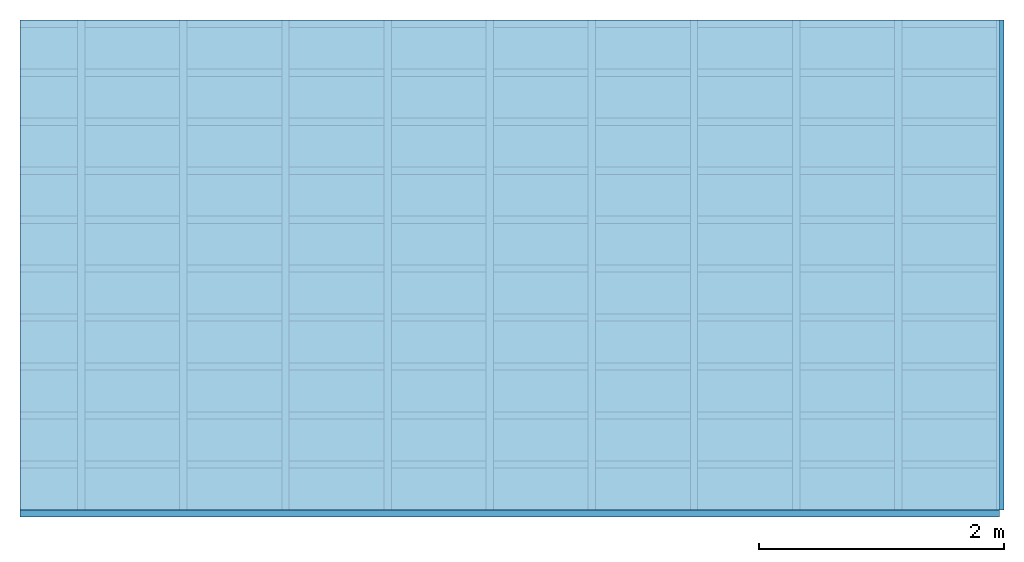
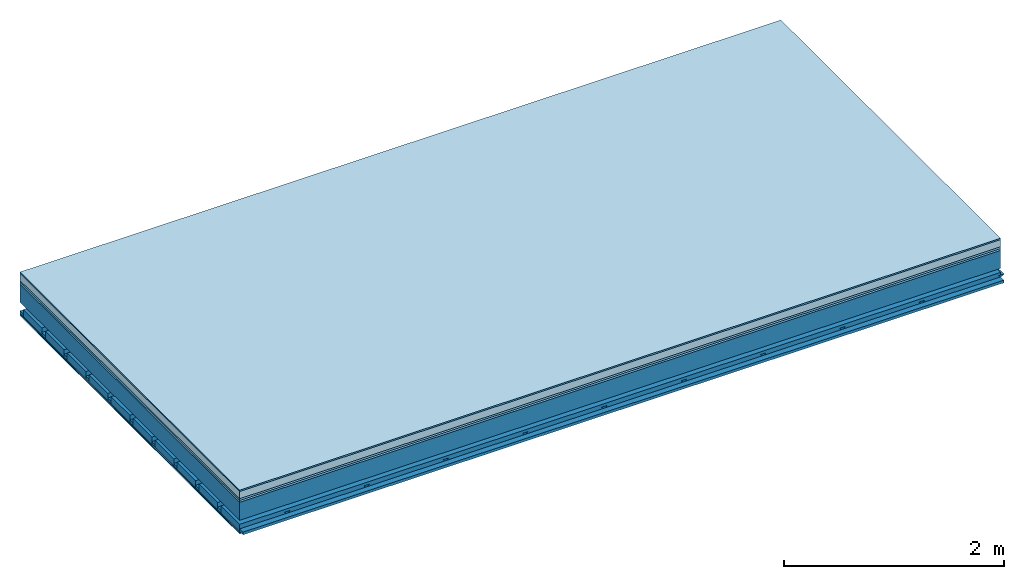
# One storey: 7 plates, 4 members, 1 element without a shape of its own.
"""IFC4 building model written with IfcOpenShell, lengths in metres."""

from ifc_helpers import new_model, si_unit, derived_unit, direction, frame, frame_2d, origin, origin_with_axes, place, context, project, spatial, polyline, rectangle, outline, extrude, material, layer, layer_set, type_object, element, aggregate, save


model = new_model("IFC4")

# Units and contexts
plan_context = context("Plan", 3, precision=1e-05, world=origin(), true_north=direction((0.0, 1.0)))
model_context = context("Model", 3, precision=1e-05, world=origin(), true_north=direction((0.0, 1.0)))
ifc_project = project(units=[si_unit("LENGTHUNIT", "METRE"), derived_unit("SOUNDPRESSUREUNIT", [(si_unit("PRESSUREUNIT", "PASCAL", prefix="MICRO"), 0)]), si_unit("ENERGYUNIT", "JOULE", prefix="MEGA"), si_unit("MASSUNIT", "GRAM", prefix="KILO"), derived_unit("THERMALTRANSMITTANCEUNIT", [(si_unit("POWERUNIT", "WATT"), 1), (si_unit("AREAUNIT", "SQUARE_METRE"), -1), (si_unit("THERMODYNAMICTEMPERATUREUNIT", "KELVIN"), -1)]), derived_unit("AREADENSITYUNIT", [(si_unit("MASSUNIT", "GRAM", prefix="KILO"), 1), (si_unit("AREAUNIT", "SQUARE_METRE"), -1)]), derived_unit("USERDEFINED", [(si_unit("ENERGYUNIT", "JOULE", prefix="MEGA"), 1), (si_unit("AREAUNIT", "SQUARE_METRE"), -1)])], contexts=[plan_context, model_context])

# Site, building, storey
site = spatial("IfcSite", under=ifc_project)
building_placement = place(None, origin())
building = spatial("IfcBuilding", under=site, at=building_placement)
storey_placement = place(building_placement, origin())
storey = spatial("IfcBuildingStorey", under=building, at=storey_placement)

# Slab, members, plates
ifc_material_1 = material(Category="11.013")
ifc_layer_1 = layer(ifc_material_1, 0.015, Name="Flooring")
ifc_material_2 = material(Name="Cement screed", Category="04.006")
ifc_layer_2 = layer(ifc_material_2, 0.08, Name="On-material")
ifc_material_3 = material(Name="Wood fiber generic product", Category="10.009")
ifc_layer_3 = layer(ifc_material_3, 0.02, Name="Impact sound insulation")
ifc_material_4 = material(Category="10.004")
ifc_layer_4 = layer(ifc_material_4, 0.02, Name="Additional insulation")
ifc_material_5 = material(Name="no composite action")
ifc_layer_5 = layer(ifc_material_5, 0.0, Name="Bond")
ifc_layer_6 = layer(None, 0.2, Name="Supporting structure")
ifc_layer_7 = layer(ifc_material_5, 0.0, Name="Bond")
ifc_layer_8 = layer(None, 0.095, Name="Coupling")
ifc_layer_9 = layer(None, 0.03, Name="Battens / profiles")
ifc_material_6 = material(Name="Plasterboard type A", Category="03.008")
ifc_layer_10 = layer(ifc_material_6, 0.0125, Name="Ceiling covering 1st layer")
ifc_layer_11 = layer(ifc_material_6, 0.0125, Name="Ceiling covering layer 2")
ifc_material_7 = material(Category="04.001")
ifc_layer_12 = layer(ifc_material_7, 0.003, Name="Surface / treatment")
ifc_layer_set = layer_set([ifc_layer_1, ifc_layer_2, ifc_layer_3, ifc_layer_4, ifc_layer_5, ifc_layer_6, ifc_layer_7, ifc_layer_8, ifc_layer_9, ifc_layer_10, ifc_layer_11, ifc_layer_12])
slab_type = type_object("IfcSlabType", Name="A2154", PredefinedType="NOTDEFINED", material=ifc_layer_set)
slab_placement = place(None, frame((0.0, 0.0, 0.0), z_axis=(0.0, 0.0, -1.0), x_axis=(1.0, 0.0, 0.0)))
slab = element("IfcSlab", 1, at=slab_placement, inside=storey, type_object=slab_type, material=ifc_layer_set, Name="Slab #1")
ifc_material_8 = material(Name="Solid timber panel")
member_1_placement = place(slab_placement, origin())
member_1 = element("IfcMember", 2, at=member_1_placement, material=ifc_material_8, Name="Supporting structure", context=plan_context, shape_type="SweptSolid", body=[
    extrude(rectangle(XDim=1.0, YDim=0.2, at=frame_2d((0.5, 0.1), x_axis=(1.0, 0.0))), frame((0.0, 4.0, 0.135), z_axis=(0.0, -1.0, 0.0), x_axis=(1.0, 0.0, 0.0)), (0.0, 0.0, 1.0), 4.0),
    extrude(rectangle(XDim=1.0, YDim=0.2, at=frame_2d((0.5, 0.1), x_axis=(1.0, 0.0))), frame((1.0, 4.0, 0.135), z_axis=(0.0, -1.0, 0.0), x_axis=(1.0, 0.0, 0.0)), (0.0, 0.0, 1.0), 4.0),
    extrude(rectangle(XDim=1.0, YDim=0.2, at=frame_2d((0.5, 0.1), x_axis=(1.0, 0.0))), frame((2.0, 4.0, 0.135), z_axis=(0.0, -1.0, 0.0), x_axis=(1.0, 0.0, 0.0)), (0.0, 0.0, 1.0), 4.0),
    extrude(rectangle(XDim=1.0, YDim=0.2, at=frame_2d((0.5, 0.1), x_axis=(1.0, 0.0))), frame((3.0, 4.0, 0.135), z_axis=(0.0, -1.0, 0.0), x_axis=(1.0, 0.0, 0.0)), (0.0, 0.0, 1.0), 4.0),
    extrude(rectangle(XDim=1.0, YDim=0.2, at=frame_2d((0.5, 0.1), x_axis=(1.0, 0.0))), frame((4.0, 4.0, 0.135), z_axis=(0.0, -1.0, 0.0), x_axis=(1.0, 0.0, 0.0)), (0.0, 0.0, 1.0), 4.0),
    extrude(rectangle(XDim=1.0, YDim=0.2, at=frame_2d((0.5, 0.1), x_axis=(1.0, 0.0))), frame((5.0, 4.0, 0.135), z_axis=(0.0, -1.0, 0.0), x_axis=(1.0, 0.0, 0.0)), (0.0, 0.0, 1.0), 4.0),
    extrude(rectangle(XDim=1.0, YDim=0.2, at=frame_2d((0.5, 0.1), x_axis=(1.0, 0.0))), frame((6.0, 4.0, 0.135), z_axis=(0.0, -1.0, 0.0), x_axis=(1.0, 0.0, 0.0)), (0.0, 0.0, 1.0), 4.0),
    extrude(rectangle(XDim=1.0, YDim=0.2, at=frame_2d((0.5, 0.1), x_axis=(1.0, 0.0))), frame((7.0, 4.0, 0.135), z_axis=(0.0, -1.0, 0.0), x_axis=(1.0, 0.0, 0.0)), (0.0, 0.0, 1.0), 4.0),
])
ifc_material_9 = material()
member_2_placement = place(slab_placement, origin())
member_2 = element("IfcMember", 3, at=member_2_placement, material=ifc_material_9, Name="Coupling", context=plan_context, shape_type="SweptSolid", body=[
    extrude(outline(polyline([(0.0, 0.0), (0.06, 0.0), (0.04, 0.02), (0.02, 0.02), (0.0, 0.0)])), frame((0.47, 4.0, 0.41), z_axis=(0.0, -1.0, 0.0), x_axis=(1.0, 0.0, 0.0)), (0.0, 0.0, 1.0), 4.0),
    extrude(outline(polyline([(0.0, 0.0), (0.06, 0.0), (0.04, 0.02), (0.02, 0.02), (0.0, 0.0)])), frame((1.304, 4.0, 0.41), z_axis=(0.0, -1.0, 0.0), x_axis=(1.0, 0.0, 0.0)), (0.0, 0.0, 1.0), 4.0),
    extrude(outline(polyline([(0.0, 0.0), (0.06, 0.0), (0.04, 0.02), (0.02, 0.02), (0.0, 0.0)])), frame((2.138, 4.0, 0.41), z_axis=(0.0, -1.0, 0.0), x_axis=(1.0, 0.0, 0.0)), (0.0, 0.0, 1.0), 4.0),
    extrude(outline(polyline([(0.0, 0.0), (0.06, 0.0), (0.04, 0.02), (0.02, 0.02), (0.0, 0.0)])), frame((2.972, 4.0, 0.41), z_axis=(0.0, -1.0, 0.0), x_axis=(1.0, 0.0, 0.0)), (0.0, 0.0, 1.0), 4.0),
    extrude(outline(polyline([(0.0, 0.0), (0.06, 0.0), (0.04, 0.02), (0.02, 0.02), (0.0, 0.0)])), frame((3.806, 4.0, 0.41), z_axis=(0.0, -1.0, 0.0), x_axis=(1.0, 0.0, 0.0)), (0.0, 0.0, 1.0), 4.0),
    extrude(outline(polyline([(0.0, 0.0), (0.06, 0.0), (0.04, 0.02), (0.02, 0.02), (0.0, 0.0)])), frame((4.64, 4.0, 0.41), z_axis=(0.0, -1.0, 0.0), x_axis=(1.0, 0.0, 0.0)), (0.0, 0.0, 1.0), 4.0),
    extrude(outline(polyline([(0.0, 0.0), (0.06, 0.0), (0.04, 0.02), (0.02, 0.02), (0.0, 0.0)])), frame((5.474, 4.0, 0.41), z_axis=(0.0, -1.0, 0.0), x_axis=(1.0, 0.0, 0.0)), (0.0, 0.0, 1.0), 4.0),
    extrude(outline(polyline([(0.0, 0.0), (0.06, 0.0), (0.04, 0.02), (0.02, 0.02), (0.0, 0.0)])), frame((6.308, 4.0, 0.41), z_axis=(0.0, -1.0, 0.0), x_axis=(1.0, 0.0, 0.0)), (0.0, 0.0, 1.0), 4.0),
    extrude(outline(polyline([(0.0, 0.0), (0.06, 0.0), (0.04, 0.02), (0.02, 0.02), (0.0, 0.0)])), frame((7.142, 4.0, 0.41), z_axis=(0.0, -1.0, 0.0), x_axis=(1.0, 0.0, 0.0)), (0.0, 0.0, 1.0), 4.0),
    extrude(outline(polyline([(0.0, 0.0), (0.06, 0.0), (0.04, 0.02), (0.02, 0.02), (0.0, 0.0)])), frame((7.976, 4.0, 0.41), z_axis=(0.0, -1.0, 0.0), x_axis=(1.0, 0.0, 0.0)), (0.0, 0.0, 1.0), 4.0),
])
member_3_placement = place(slab_placement, origin())
member_3 = element("IfcMember", 4, at=member_3_placement, material=ifc_material_9, Name="Battens / profiles", context=plan_context, shape_type="SweptSolid", body=[
    extrude(rectangle(XDim=0.06, YDim=0.03, at=frame_2d((0.03, 0.015), x_axis=(1.0, 0.0))), frame((0.0, 0.0, 0.43), z_axis=(1.0, 0.0, 0.0), x_axis=(0.0, 1.0, 0.0)), (0.0, 0.0, 1.0), 8.0),
    extrude(rectangle(XDim=0.06, YDim=0.03, at=frame_2d((0.03, 0.015), x_axis=(1.0, 0.0))), frame((0.0, 0.4, 0.43), z_axis=(1.0, 0.0, 0.0), x_axis=(0.0, 1.0, 0.0)), (0.0, 0.0, 1.0), 8.0),
    extrude(rectangle(XDim=0.06, YDim=0.03, at=frame_2d((0.03, 0.015), x_axis=(1.0, 0.0))), frame((0.0, 0.8, 0.43), z_axis=(1.0, 0.0, 0.0), x_axis=(0.0, 1.0, 0.0)), (0.0, 0.0, 1.0), 8.0),
    extrude(rectangle(XDim=0.06, YDim=0.03, at=frame_2d((0.03, 0.015), x_axis=(1.0, 0.0))), frame((0.0, 1.2, 0.43), z_axis=(1.0, 0.0, 0.0), x_axis=(0.0, 1.0, 0.0)), (0.0, 0.0, 1.0), 8.0),
    extrude(rectangle(XDim=0.06, YDim=0.03, at=frame_2d((0.03, 0.015), x_axis=(1.0, 0.0))), frame((0.0, 1.6, 0.43), z_axis=(1.0, 0.0, 0.0), x_axis=(0.0, 1.0, 0.0)), (0.0, 0.0, 1.0), 8.0),
    extrude(rectangle(XDim=0.06, YDim=0.03, at=frame_2d((0.03, 0.015), x_axis=(1.0, 0.0))), frame((0.0, 2.0, 0.43), z_axis=(1.0, 0.0, 0.0), x_axis=(0.0, 1.0, 0.0)), (0.0, 0.0, 1.0), 8.0),
    extrude(rectangle(XDim=0.06, YDim=0.03, at=frame_2d((0.03, 0.015), x_axis=(1.0, 0.0))), frame((0.0, 2.4, 0.43), z_axis=(1.0, 0.0, 0.0), x_axis=(0.0, 1.0, 0.0)), (0.0, 0.0, 1.0), 8.0),
    extrude(rectangle(XDim=0.06, YDim=0.03, at=frame_2d((0.03, 0.015), x_axis=(1.0, 0.0))), frame((0.0, 2.8, 0.43), z_axis=(1.0, 0.0, 0.0), x_axis=(0.0, 1.0, 0.0)), (0.0, 0.0, 1.0), 8.0),
    extrude(rectangle(XDim=0.06, YDim=0.03, at=frame_2d((0.03, 0.015), x_axis=(1.0, 0.0))), frame((0.0, 3.2, 0.43), z_axis=(1.0, 0.0, 0.0), x_axis=(0.0, 1.0, 0.0)), (0.0, 0.0, 1.0), 8.0),
    extrude(rectangle(XDim=0.06, YDim=0.03, at=frame_2d((0.03, 0.015), x_axis=(1.0, 0.0))), frame((0.0, 3.6, 0.43), z_axis=(1.0, 0.0, 0.0), x_axis=(0.0, 1.0, 0.0)), (0.0, 0.0, 1.0), 8.0),
    extrude(rectangle(XDim=0.06, YDim=0.03, at=frame_2d((0.03, 0.015), x_axis=(1.0, 0.0))), frame((0.0, 4.0, 0.43), z_axis=(1.0, 0.0, 0.0), x_axis=(0.0, 1.0, 0.0)), (0.0, 0.0, 1.0), 8.0),
])
ifc_material_10 = material()
member_4_placement = place(slab_placement, origin())
member_4 = element("IfcMember", 5, at=member_4_placement, material=ifc_material_10, Name="Cavity", context=plan_context, shape_type="SweptSolid", body=[
    extrude(rectangle(XDim=0.34, YDim=0.08, at=frame_2d((0.17, 0.04), x_axis=(1.0, 0.0))), frame((0.0, 0.06, 0.38), z_axis=(1.0, 0.0, 0.0), x_axis=(0.0, 1.0, 0.0)), (0.0, 0.0, 1.0), 8.0),
    extrude(rectangle(XDim=0.34, YDim=0.08, at=frame_2d((0.17, 0.04), x_axis=(1.0, 0.0))), frame((0.0, 0.46, 0.38), z_axis=(1.0, 0.0, 0.0), x_axis=(0.0, 1.0, 0.0)), (0.0, 0.0, 1.0), 8.0),
    extrude(rectangle(XDim=0.34, YDim=0.08, at=frame_2d((0.17, 0.04), x_axis=(1.0, 0.0))), frame((0.0, 0.86, 0.38), z_axis=(1.0, 0.0, 0.0), x_axis=(0.0, 1.0, 0.0)), (0.0, 0.0, 1.0), 8.0),
    extrude(rectangle(XDim=0.34, YDim=0.08, at=frame_2d((0.17, 0.04), x_axis=(1.0, 0.0))), frame((0.0, 1.26, 0.38), z_axis=(1.0, 0.0, 0.0), x_axis=(0.0, 1.0, 0.0)), (0.0, 0.0, 1.0), 8.0),
    extrude(rectangle(XDim=0.34, YDim=0.08, at=frame_2d((0.17, 0.04), x_axis=(1.0, 0.0))), frame((0.0, 1.66, 0.38), z_axis=(1.0, 0.0, 0.0), x_axis=(0.0, 1.0, 0.0)), (0.0, 0.0, 1.0), 8.0),
    extrude(rectangle(XDim=0.34, YDim=0.08, at=frame_2d((0.17, 0.04), x_axis=(1.0, 0.0))), frame((0.0, 2.06, 0.38), z_axis=(1.0, 0.0, 0.0), x_axis=(0.0, 1.0, 0.0)), (0.0, 0.0, 1.0), 8.0),
    extrude(rectangle(XDim=0.34, YDim=0.08, at=frame_2d((0.17, 0.04), x_axis=(1.0, 0.0))), frame((0.0, 2.46, 0.38), z_axis=(1.0, 0.0, 0.0), x_axis=(0.0, 1.0, 0.0)), (0.0, 0.0, 1.0), 8.0),
    extrude(rectangle(XDim=0.34, YDim=0.08, at=frame_2d((0.17, 0.04), x_axis=(1.0, 0.0))), frame((0.0, 2.86, 0.38), z_axis=(1.0, 0.0, 0.0), x_axis=(0.0, 1.0, 0.0)), (0.0, 0.0, 1.0), 8.0),
    extrude(rectangle(XDim=0.34, YDim=0.08, at=frame_2d((0.17, 0.04), x_axis=(1.0, 0.0))), frame((0.0, 3.26, 0.38), z_axis=(1.0, 0.0, 0.0), x_axis=(0.0, 1.0, 0.0)), (0.0, 0.0, 1.0), 8.0),
    extrude(rectangle(XDim=0.34, YDim=0.08, at=frame_2d((0.17, 0.04), x_axis=(1.0, 0.0))), frame((0.0, 3.66, 0.38), z_axis=(1.0, 0.0, 0.0), x_axis=(0.0, 1.0, 0.0)), (0.0, 0.0, 1.0), 8.0),
])
plate_1_placement = place(slab_placement, origin())
plate_1 = element("IfcPlate", 6, at=plate_1_placement, material=ifc_material_1, Name="Flooring", context=plan_context, shape_type="SweptSolid", body=[
    extrude(rectangle(XDim=8.0, YDim=4.0, at=frame_2d((4.0, 2.0), x_axis=(1.0, 0.0))), origin_with_axes(), (0.0, 0.0, 1.0), 0.015),
])
plate_2_placement = place(slab_placement, origin())
plate_2 = element("IfcPlate", 7, at=plate_2_placement, material=ifc_material_2, Name="On-material", context=plan_context, shape_type="SweptSolid", body=[
    extrude(rectangle(XDim=8.0, YDim=4.0, at=frame_2d((4.0, 2.0), x_axis=(1.0, 0.0))), frame((0.0, 0.0, 0.015), z_axis=(0.0, 0.0, 1.0), x_axis=(1.0, 0.0, 0.0)), (0.0, 0.0, 1.0), 0.08),
])
plate_3_placement = place(slab_placement, origin())
plate_3 = element("IfcPlate", 8, at=plate_3_placement, material=ifc_material_3, Name="Impact sound insulation", context=plan_context, shape_type="SweptSolid", body=[
    extrude(rectangle(XDim=8.0, YDim=4.0, at=frame_2d((4.0, 2.0), x_axis=(1.0, 0.0))), frame((0.0, 0.0, 0.095), z_axis=(0.0, 0.0, 1.0), x_axis=(1.0, 0.0, 0.0)), (0.0, 0.0, 1.0), 0.02),
])
plate_4_placement = place(slab_placement, origin())
plate_4 = element("IfcPlate", 9, at=plate_4_placement, material=ifc_material_4, Name="Additional insulation", context=plan_context, shape_type="SweptSolid", body=[
    extrude(rectangle(XDim=8.0, YDim=4.0, at=frame_2d((4.0, 2.0), x_axis=(1.0, 0.0))), frame((0.0, 0.0, 0.115), z_axis=(0.0, 0.0, 1.0), x_axis=(1.0, 0.0, 0.0)), (0.0, 0.0, 1.0), 0.02),
])
plate_5_placement = place(slab_placement, origin())
plate_5 = element("IfcPlate", 10, at=plate_5_placement, material=ifc_material_6, Name="Ceiling covering 1st layer", context=plan_context, shape_type="SweptSolid", body=[
    extrude(rectangle(XDim=8.0, YDim=4.0, at=frame_2d((4.0, 2.0), x_axis=(1.0, 0.0))), frame((0.0, 0.0, 0.46), z_axis=(0.0, 0.0, 1.0), x_axis=(1.0, 0.0, 0.0)), (0.0, 0.0, 1.0), 0.0125),
])
plate_6_placement = place(slab_placement, origin())
plate_6 = element("IfcPlate", 11, at=plate_6_placement, material=ifc_material_6, Name="Ceiling covering layer 2", context=plan_context, shape_type="SweptSolid", body=[
    extrude(rectangle(XDim=8.0, YDim=4.0, at=frame_2d((4.0, 2.0), x_axis=(1.0, 0.0))), frame((0.0, 0.0, 0.4725), z_axis=(0.0, 0.0, 1.0), x_axis=(1.0, 0.0, 0.0)), (0.0, 0.0, 1.0), 0.0125),
])
plate_7_placement = place(slab_placement, origin())
plate_7 = element("IfcPlate", 12, at=plate_7_placement, material=ifc_material_7, Name="Surface / treatment", context=plan_context, shape_type="SweptSolid", body=[
    extrude(rectangle(XDim=8.0, YDim=4.0, at=frame_2d((4.0, 2.0), x_axis=(1.0, 0.0))), frame((0.0, 0.0, 0.485), z_axis=(0.0, 0.0, 1.0), x_axis=(1.0, 0.0, 0.0)), (0.0, 0.0, 1.0), 0.003),
])
aggregate(slab, [plate_1, plate_2, plate_3, plate_4, member_1, member_2, member_3, member_4, plate_5, plate_6, plate_7])

save(model, "model.ifc")
